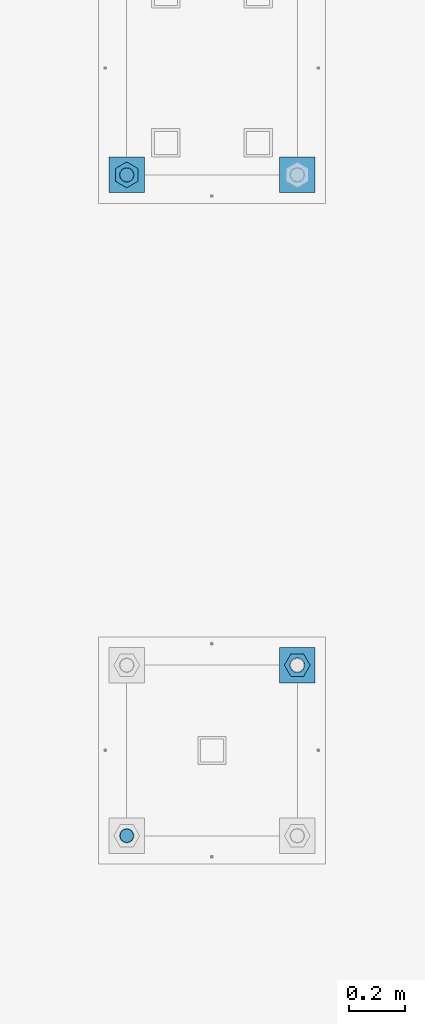
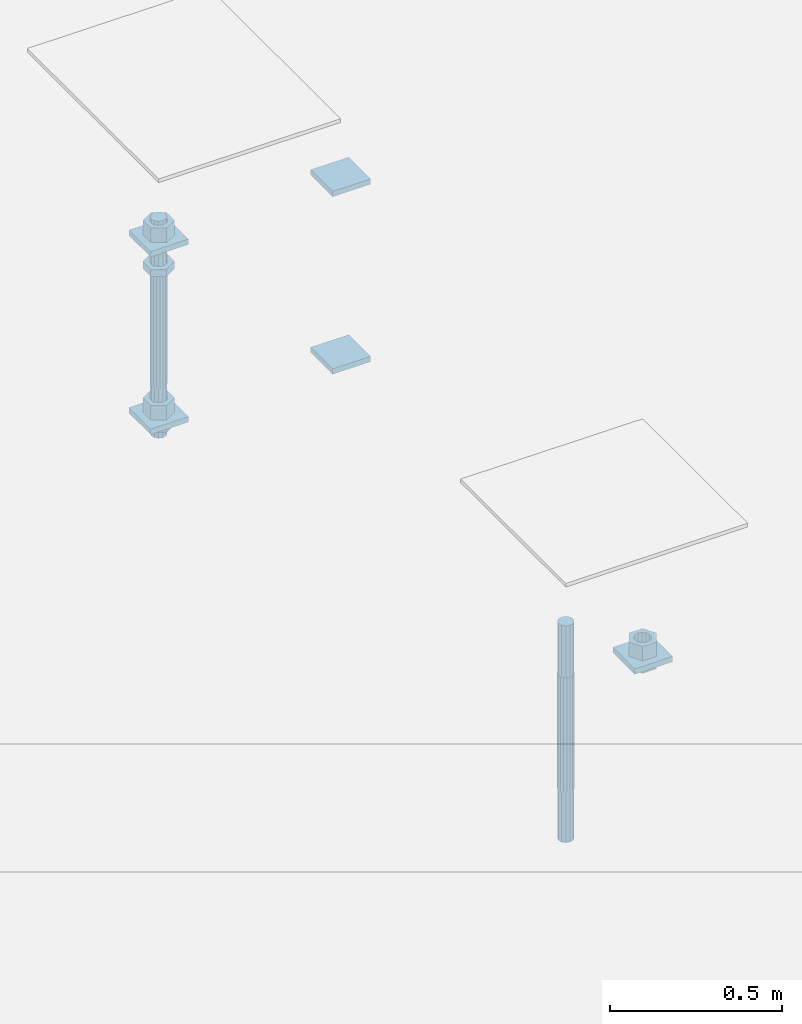
# One storey, part 2729 of 3843: 13 beams, 2 elements without a shape of their own.
"""IFC2X3 building model written with IfcOpenShell, lengths in millimetres."""

import ifcopenshell
import ifcopenshell.guid

model = None  # the IFC model being written
_history = None  # IfcOwnerHistory: only IFC2X3 demands one
_inside = {}  # id of a spatial element -> (the spatial element, [elements in it])
_under = {}  # id of a project, library or spatial element -> (it, [spatial elements below it])
_declared = {}  # id of a project -> (the project, [libraries it declares])
_typed = {}  # id of a type object -> (the type object, [elements of that type])
_made_of = {}  # id of a material, layer set ... -> (it, [elements and type objects made of it])


def new_model(schema):
    """Start an empty IFC model of exactly this schema.

    Asked for "IFC4X3", IfcOpenShell would pick the latest addendum, in which some entities
    have other attributes; the version numbers below select the first issue.
    IFC2X3 requires an IfcOwnerHistory on every rooted entity: one is made here for all.
    """
    global model, _history
    if schema == "IFC4X3":
        model = ifcopenshell.file(schema_version=(4, 3, 0, 0))
    else:
        model = ifcopenshell.file(schema=schema)
    _inside.clear()
    _under.clear()
    _declared.clear()
    _typed.clear()
    _made_of.clear()
    _history = None
    if model.schema == "IFC2X3":
        org = make("IfcOrganization", Name="unknown")
        user = make(
            "IfcPersonAndOrganization",
            ThePerson=make("IfcPerson", FamilyName="unknown"),
            TheOrganization=org,
        )
        app = make(
            "IfcApplication",
            ApplicationDeveloper=org,
            Version="unknown",
            ApplicationFullName="unknown",
            ApplicationIdentifier="unknown",
        )
        _history = make(
            "IfcOwnerHistory",
            OwningUser=user,
            OwningApplication=app,
            ChangeAction="ADDED",
            CreationDate=0,
        )
    return model


def make(cls, **values):
    """One entity of the class cls with the attributes given. An attribute that is None is left unset."""
    return model.create_entity(
        cls, **{name: value for name, value in values.items() if value is not None}
    )


def rooted(cls, **values):
    """An entity with a GlobalId (a new one), such as an element, a storey or a relation."""
    return make(cls, GlobalId=ifcopenshell.guid.new(), OwnerHistory=_history, **values)


def si_unit(unit_type, name, prefix=None):
    """IfcSIUnit, for example si_unit("LENGTHUNIT", "METRE", prefix="MILLI")."""
    return make("IfcSIUnit", UnitType=unit_type, Prefix=prefix, Name=name)


def assignment(units):
    """IfcUnitAssignment: the units of a project."""
    return None if units is None else make("IfcUnitAssignment", Units=units)


def point(xyz):
    """IfcCartesianPoint."""
    return None if xyz is None else make("IfcCartesianPoint", Coordinates=xyz)


def direction(xyz):
    """IfcDirection."""
    return None if xyz is None else make("IfcDirection", DirectionRatios=xyz)


def frame(location, z_axis=None, x_axis=None):
    """IfcAxis2Placement3D, a coordinate frame: its origin and axes. An axis left out is left unset."""
    return make(
        "IfcAxis2Placement3D",
        Location=point(location),
        Axis=direction(z_axis),
        RefDirection=direction(x_axis),
    )


def origin_with_axes():
    """The frame at (0, 0, 0) with the z axis (0, 0, 1) and the x axis (1, 0, 0) written out."""
    return frame((0.0, 0.0, 0.0), z_axis=(0.0, 0.0, 1.0), x_axis=(1.0, 0.0, 0.0))


def place(relative_to, where):
    """IfcLocalPlacement: puts the frame where relative to a parent placement (None: the world)."""
    return make(
        "IfcLocalPlacement", PlacementRelTo=relative_to, RelativePlacement=where
    )


def context(
    kind, dimensions, precision=None, world=None, true_north=None, identifier=None
):
    """IfcGeometricRepresentationContext, for example the 3D "Model" context."""
    return make(
        "IfcGeometricRepresentationContext",
        ContextIdentifier=identifier,
        ContextType=kind,
        CoordinateSpaceDimension=dimensions,
        Precision=precision,
        WorldCoordinateSystem=world,
        TrueNorth=true_north,
    )


def subcontext(parent, identifier, kind, view, scale=None):
    """IfcGeometricRepresentationSubContext, for example "Body" below "Model"."""
    return make(
        "IfcGeometricRepresentationSubContext",
        ContextIdentifier=identifier,
        ContextType=kind,
        ParentContext=parent,
        TargetScale=scale,
        TargetView=view,
    )


def project(units=None, contexts=None):
    """IfcProject with its units and contexts."""
    return rooted(
        "IfcProject",
        Name="project",
        RepresentationContexts=contexts,
        UnitsInContext=assignment(units),
    )


def spatial(cls, under=None, at=None, **own):
    """A site, building, storey or space (cls), placed at a placement, below another one or the project."""
    s = rooted(cls, ObjectPlacement=at, **own)
    if under is not None:
        _under.setdefault(under.id(), (under, []))[1].append(s)
    return s


def faces_of(points, faces, orient=None, outer=None):
    """IfcFace entities. A face is a list of loops; a loop is a list of indices into points, from 0.

    orient and outer hold one flag for each loop. By default every Orientation is true, the
    first loop of a face is its IfcFaceOuterBound and the others are IfcFaceBound.
    """
    made = []
    for i, loops in enumerate(faces):
        bounds = []
        for j, loop in enumerate(loops):
            is_outer = j == 0 if outer is None else outer[i][j]
            bounds.append(
                make(
                    "IfcFaceOuterBound" if is_outer else "IfcFaceBound",
                    Bound=make("IfcPolyLoop", Polygon=[points[k] for k in loop]),
                    Orientation=True if orient is None else orient[i][j],
                )
            )
        made.append(make("IfcFace", Bounds=bounds))
    return made


def faceted_brep(points, faces, orient=None, outer=None, voids=None):
    """IfcFacetedBrep: a solid bounded by flat faces; with voids (closed shells), ...WithVoids."""
    shared = [point(p) for p in points]
    hull = make("IfcClosedShell", CfsFaces=faces_of(shared, faces, orient, outer))
    if voids is None:
        return make("IfcFacetedBrep", Outer=hull)
    return make(
        "IfcFacetedBrepWithVoids",
        Outer=hull,
        Voids=[
            make(cls, CfsFaces=faces_of(shared, fs, o, b)) for cls, fs, o, b in voids
        ],
    )


def shape(context_of_items, identifier, shape_type, items):
    """IfcShapeRepresentation: the items that make up one representation, for example the "Body"."""
    return make(
        "IfcShapeRepresentation",
        ContextOfItems=context_of_items,
        RepresentationIdentifier=identifier,
        RepresentationType=shape_type,
        Items=items,
    )


def material(Name=None, Category=None):
    """IfcMaterial."""
    return make("IfcMaterial", Name=Name, Category=Category)


def made_of(thing, what):
    """Note that an element or type object is made of a material, layer set ...; save() writes the relation."""
    if what is not None:
        _made_of.setdefault(what.id(), (what, []))[1].append(thing)
    return thing


def type_object(cls, material=None, **own):
    """A type object (cls), such as IfcWallType, which elements share."""
    return made_of(rooted(cls, **own), material)


def element(
    cls,
    number,
    at=None,
    inside=None,
    cuts=None,
    type_object=None,
    material=None,
    context=None,
    identifier="Body",
    shape_type=None,
    held_by="IfcProductDefinitionShape",
    body=None,
    shapes=None,
    **own,
):
    """One element of the class cls, such as IfcWall. Its Tag is "e" and its number.

    at: its placement. inside: the storey or other place that contains it. cuts: it is an
    opening in that element (IfcRelVoidsElement). A single representation is given by context,
    identifier, shape_type and body (its items); several are given by shapes. held_by: the class
    of the entity that holds the representations. save() writes the other relations.
    """
    e = rooted(cls, Tag="e%d" % number, ObjectPlacement=at, **own)
    if body is not None:
        shapes = [shape(context, identifier, shape_type, body)]
    if shapes is not None:
        e.Representation = make(held_by, Representations=shapes)
    if inside is not None:
        _inside.setdefault(inside.id(), (inside, []))[1].append(e)
    if cuts is not None:
        rooted(
            "IfcRelVoidsElement", RelatingBuildingElement=cuts, RelatedOpeningElement=e
        )
    if type_object is not None:
        _typed.setdefault(type_object.id(), (type_object, []))[1].append(e)
    return made_of(e, material)


def aggregate(whole, parts):
    """IfcRelAggregates: a whole, such as a stair, and the parts it consists of."""
    return rooted("IfcRelAggregates", RelatingObject=whole, RelatedObjects=parts)


def save(model, path):
    """Write the relations noted so far, then the file.

    IfcRelAggregates (storeys below a building ...), IfcRelContainedInSpatialStructure (elements
    in a storey), IfcRelDefinesByType, IfcRelAssociatesMaterial and IfcRelDeclares: one each for
    every whole, place, type object, material and project.
    """
    for whole, parts in _under.values():
        aggregate(whole, parts)
    for where, things in _inside.values():
        rooted(
            "IfcRelContainedInSpatialStructure",
            RelatedElements=things,
            RelatingStructure=where,
        )
    for kind, things in _typed.values():
        rooted("IfcRelDefinesByType", RelatedObjects=things, RelatingType=kind)
    for what, things in _made_of.values():
        rooted("IfcRelAssociatesMaterial", RelatedObjects=things, RelatingMaterial=what)
    for by, libraries in _declared.values():
        rooted("IfcRelDeclares", RelatingContext=by, RelatedDefinitions=libraries)
    model.write(path)


model = new_model("IFC2X3")

# Units and contexts
model_context = context("Model", 3, precision=1e-05, world=origin_with_axes())
body_context = subcontext(model_context, "Body", "Model", "MODEL_VIEW")
ifc_project = project(units=[si_unit("LENGTHUNIT", "METRE", prefix="MILLI"), si_unit("AREAUNIT", "SQUARE_METRE"), si_unit("VOLUMEUNIT", "CUBIC_METRE"), si_unit("MASSUNIT", "GRAM", prefix="KILO"), si_unit("TIMEUNIT", "SECOND"), si_unit("PLANEANGLEUNIT", "RADIAN"), si_unit("SOLIDANGLEUNIT", "STERADIAN"), si_unit("THERMODYNAMICTEMPERATUREUNIT", "DEGREE_CELSIUS"), si_unit("LUMINOUSINTENSITYUNIT", "LUMEN")], contexts=[model_context])

# Site, building, storey
site_placement = place(None, origin_with_axes())
site = spatial("IfcSite", under=ifc_project, at=site_placement, CompositionType="ELEMENT")
building_placement = place(site_placement, origin_with_axes())
building = spatial("IfcBuilding", under=site, at=building_placement, Name="Undefined", CompositionType="ELEMENT")
storey_placement = place(building_placement, origin_with_axes())
storey = spatial("IfcBuildingStorey", under=building, at=storey_placement, Name="Undefined", CompositionType="ELEMENT", Elevation=0.0)

# Assembly, beams
assembly_1_placement = place(storey_placement, origin_with_axes())
assembly_1 = element("IfcElementAssembly", 1, at=assembly_1_placement, inside=storey, Name="TEMPLATE", AssemblyPlace="NOTDEFINED", PredefinedType="RIGID_FRAME")
ifc_material_1 = material(Name="STEEL/A36")
beam_type_1 = type_object("IfcBeamType", PredefinedType="NOTDEFINED")
beam_1_placement = place(assembly_1_placement, frame((111798.099998474, 38176.2, 29873.575), z_axis=(0.0, 1.0, 0.0), x_axis=(-1.0, 0.0, 0.0)))
beam_1 = element("IfcBeam", 2, at=beam_1_placement, type_object=beam_type_1, material=ifc_material_1, Name="WASHER_PLATE", context=body_context, shape_type="Brep", body=[
    faceted_brep([(0.0, 9.52500000000146, -63.5), (0.0, 9.52500000000146, 63.5), (127.0, 9.52500000000146, 63.5), (127.0, 9.52500000000146, -63.5), (0.0, -9.52500000000146, 63.5), (127.0, -9.52500000000146, 63.5), (0.0, -9.52500000000146, -63.5), (127.0, -9.52500000000146, -63.5)], [[[0, 1, 2, 3]], [[1, 4, 5, 2]], [[4, 6, 7, 5]], [[6, 0, 3, 7]], [[5, 7, 3, 2]], [[6, 4, 1, 0]]]),
])
beam_2_placement = place(assembly_1_placement, frame((112407.7, 38176.2, 29873.575), z_axis=(0.0, 1.0, 0.0), x_axis=(-1.0, 0.0, 0.0)))
beam_2 = element("IfcBeam", 3, at=beam_2_placement, type_object=beam_type_1, material=ifc_material_1, Name="WASHER_PLATE", context=body_context, shape_type="Brep", body=[
    faceted_brep([(0.0, 9.52500000000146, -63.5), (0.0, 9.52500000000146, 63.5), (127.0, 9.52500000000146, 63.5), (127.0, 9.52500000000146, -63.5), (0.0, -9.52500000000146, 63.5), (127.0, -9.52500000000146, 63.5), (0.0, -9.52500000000146, -63.5), (127.0, -9.52500000000146, -63.5)], [[[0, 1, 2, 3]], [[1, 4, 5, 2]], [[4, 6, 7, 5]], [[6, 0, 3, 7]], [[5, 7, 3, 2]], [[6, 4, 1, 0]]]),
])
beam_3_placement = place(assembly_1_placement, frame((111798.099998474, 38176.2, 29244.925), z_axis=(0.0, 1.0, 0.0), x_axis=(-1.0, 0.0, 0.0)))
beam_3 = element("IfcBeam", 4, at=beam_3_placement, type_object=beam_type_1, material=ifc_material_1, Name="WASHER_PLATE", context=body_context, shape_type="Brep", body=[
    faceted_brep([(0.0, 9.52500000000146, -63.5), (0.0, 9.52500000000146, 63.5), (127.0, 9.52500000000146, 63.5), (127.0, 9.52500000000146, -63.5), (0.0, -9.52500000000146, 63.5), (127.0, -9.52500000000146, 63.5), (0.0, -9.52500000000146, -63.5), (127.0, -9.52500000000146, -63.5)], [[[0, 1, 2, 3]], [[1, 4, 5, 2]], [[4, 6, 7, 5]], [[6, 0, 3, 7]], [[5, 7, 3, 2]], [[6, 4, 1, 0]]]),
])
beam_4_placement = place(assembly_1_placement, frame((112407.7, 38176.2, 29244.925), z_axis=(0.0, 1.0, 0.0), x_axis=(-1.0, 0.0, 0.0)))
beam_4 = element("IfcBeam", 5, at=beam_4_placement, type_object=beam_type_1, material=ifc_material_1, Name="WASHER_PLATE", context=body_context, shape_type="Brep", body=[
    faceted_brep([(0.0, 9.52500000000146, -63.5), (0.0, 9.52500000000146, 63.5), (127.0, 9.52500000000146, 63.5), (127.0, 9.52500000000146, -63.5), (0.0, -9.52500000000146, 63.5), (127.0, -9.52500000000146, 63.5), (0.0, -9.52500000000146, -63.5), (127.0, -9.52500000000146, -63.5)], [[[0, 1, 2, 3]], [[1, 4, 5, 2]], [[4, 6, 7, 5]], [[6, 0, 3, 7]], [[5, 7, 3, 2]], [[6, 4, 1, 0]]]),
])

# Assembly, beam
assembly_2_placement = place(storey_placement, origin_with_axes())
assembly_2 = element("IfcElementAssembly", 6, at=assembly_2_placement, inside=storey, Name="TEMPLATE", AssemblyPlace="NOTDEFINED", PredefinedType="RIGID_FRAME")
beam_5_placement = place(assembly_2_placement, frame((112344.2, 36360.1000015259, 29244.925), z_axis=(1.0, 0.0, 0.0), x_axis=(0.0, 1.0, 0.0)))
beam_5 = element("IfcBeam", 7, at=beam_5_placement, type_object=beam_type_1, material=ifc_material_1, Name="WASHER_PLATE", context=body_context, shape_type="Brep", body=[
    faceted_brep([(0.0, 9.52500000000146, -63.5), (0.0, 9.52500000000146, 63.5), (127.0, 9.52500000000146, 63.5), (127.0, 9.52500000000146, -63.5), (0.0, -9.52500000000146, 63.5), (127.0, -9.52500000000146, 63.5), (0.0, -9.52500000000146, -63.5), (127.0, -9.52500000000146, -63.5)], [[[0, 1, 2, 3]], [[1, 4, 5, 2]], [[4, 6, 7, 5]], [[6, 0, 3, 7]], [[5, 7, 3, 2]], [[6, 4, 1, 0]]]),
])

# Beam
beam_type_2 = type_object("IfcBeamType", Name="2_HALF_NUT", PredefinedType="NOTDEFINED")
beam_6_placement = place(assembly_1_placement, frame((111734.599998474, 38176.2, 29787.85), z_axis=(-1.0, 0.0, 0.0), x_axis=(0.0, 0.0, -1.0)))
beam_6 = element("IfcBeam", 8, at=beam_6_placement, type_object=beam_type_2, material=ifc_material_1, Name="NUT", ObjectType="2_HALF_NUT", context=body_context, shape_type="Brep", body=[
    faceted_brep([(0.0, -46.0369987487793, 0.0), (0.0, -23.0184993743896, -39.869213104248), (25.4000000000015, -23.0184993743896, -39.869213104248), (25.4000000000015, -46.0369987487793, 0.0), (0.0, 23.0184993743896, -39.869213104248), (25.4000000000015, 23.0184993743896, -39.869213104248), (0.0, 46.0369987487793, 0.0), (25.4000000000015, 46.0369987487793, 0.0), (0.0, 23.0184993743896, 39.869213104248), (25.4000000000015, 23.0184993743896, 39.869213104248), (0.0, -23.0184993743896, 39.869213104248), (25.4000000000015, -23.0184993743896, 39.869213104248), (0.0, 0.0, 26.1940002441406), (0.0, 11.3650617044477, 23.5999013092805), (25.4000000000015, 11.3650617044477, 23.5999013092805), (25.4000000000015, 0.0, 26.1940002441406), (0.0, 20.4791109456419, 16.3316083006721), (25.4000000000015, 20.4791109456419, 16.3316083006721), (0.0, 25.5370200498292, 5.82867859874386), (25.4000000000015, 25.5370200498292, 5.82867859874386), (0.0, 25.5370200498292, -5.82867859874386), (25.4000000000015, 25.5370200498292, -5.82867859874386), (0.0, 20.4791109456419, -16.3316083006721), (25.4000000000015, 20.4791109456419, -16.3316083006721), (0.0, 11.3650617044477, -23.5999013092805), (25.4000000000015, 11.3650617044477, -23.5999013092805), (0.0, 0.0, -26.1940002441406), (25.4000000000015, 0.0, -26.1940002441406), (0.0, -11.3650617044477, -23.5999013092805), (25.4000000000015, -11.3650617044477, -23.5999013092805), (0.0, -20.4791109456419, -16.3316083006721), (25.4000000000015, -20.4791109456419, -16.3316083006721), (0.0, -25.5370200498292, -5.82867859874386), (25.4000000000015, -25.5370200498292, -5.82867859874386), (0.0, -25.5370200498292, 5.82867859874386), (25.4000000000015, -25.5370200498292, 5.82867859874386), (0.0, -20.4791109456419, 16.3316083006721), (25.4000000000015, -20.4791109456419, 16.3316083006721), (0.0, -11.3650617044477, 23.5999013092805), (25.4000000000015, -11.3650617044477, 23.5999013092805)], [[[0, 1, 2, 3]], [[1, 4, 5, 2]], [[4, 6, 7, 5]], [[6, 8, 9, 7]], [[8, 10, 11, 9]], [[10, 0, 3, 11]], [[12, 13, 14, 15]], [[13, 16, 17, 14]], [[16, 18, 19, 17]], [[18, 20, 21, 19]], [[20, 22, 23, 21]], [[22, 24, 25, 23]], [[24, 26, 27, 25]], [[26, 28, 29, 27]], [[28, 30, 31, 29]], [[30, 32, 33, 31]], [[32, 34, 35, 33]], [[34, 36, 37, 35]], [[36, 38, 39, 37]], [[38, 12, 15, 39]], [[5, 7, 9, 11, 3, 2], [17, 19, 21, 23, 25, 27, 29, 31, 33, 35, 37, 39, 15, 14]], [[10, 8, 6, 4, 1, 0], [38, 36, 34, 32, 30, 28, 26, 24, 22, 20, 18, 16, 13, 12]]]),
])

beam_7_placement = place(assembly_1_placement, frame((111734.599998474, 38176.2, 29235.4), z_axis=(-1.0, 0.0, 0.0), x_axis=(0.0, 0.0, -1.0)))
beam_7 = element("IfcBeam", 9, at=beam_7_placement, type_object=beam_type_2, material=ifc_material_1, Name="NUT", ObjectType="2_HALF_NUT", context=body_context, shape_type="Brep", body=[
    faceted_brep([(0.0, -46.0369987487793, 0.0), (0.0, -23.0184993743896, -39.869213104248), (25.4000000000015, -23.0184993743896, -39.869213104248), (25.4000000000015, -46.0369987487793, 0.0), (0.0, 23.0184993743896, -39.869213104248), (25.4000000000015, 23.0184993743896, -39.869213104248), (0.0, 46.0369987487793, 0.0), (25.4000000000015, 46.0369987487793, 0.0), (0.0, 23.0184993743896, 39.869213104248), (25.4000000000015, 23.0184993743896, 39.869213104248), (0.0, -23.0184993743896, 39.869213104248), (25.4000000000015, -23.0184993743896, 39.869213104248), (0.0, 0.0, 26.1940002441406), (0.0, 11.3650617044477, 23.5999013092805), (25.4000000000015, 11.3650617044477, 23.5999013092805), (25.4000000000015, 0.0, 26.1940002441406), (0.0, 20.4791109456419, 16.3316083006721), (25.4000000000015, 20.4791109456419, 16.3316083006721), (0.0, 25.5370200498292, 5.82867859874386), (25.4000000000015, 25.5370200498292, 5.82867859874386), (0.0, 25.5370200498292, -5.82867859874386), (25.4000000000015, 25.5370200498292, -5.82867859874386), (0.0, 20.4791109456419, -16.3316083006721), (25.4000000000015, 20.4791109456419, -16.3316083006721), (0.0, 11.3650617044477, -23.5999013092805), (25.4000000000015, 11.3650617044477, -23.5999013092805), (0.0, 0.0, -26.1940002441406), (25.4000000000015, 0.0, -26.1940002441406), (0.0, -11.3650617044477, -23.5999013092805), (25.4000000000015, -11.3650617044477, -23.5999013092805), (0.0, -20.4791109456419, -16.3316083006721), (25.4000000000015, -20.4791109456419, -16.3316083006721), (0.0, -25.5370200498292, -5.82867859874386), (25.4000000000015, -25.5370200498292, -5.82867859874386), (0.0, -25.5370200498292, 5.82867859874386), (25.4000000000015, -25.5370200498292, 5.82867859874386), (0.0, -20.4791109456419, 16.3316083006721), (25.4000000000015, -20.4791109456419, 16.3316083006721), (0.0, -11.3650617044477, 23.5999013092805), (25.4000000000015, -11.3650617044477, 23.5999013092805)], [[[0, 1, 2, 3]], [[1, 4, 5, 2]], [[4, 6, 7, 5]], [[6, 8, 9, 7]], [[8, 10, 11, 9]], [[10, 0, 3, 11]], [[12, 13, 14, 15]], [[13, 16, 17, 14]], [[16, 18, 19, 17]], [[18, 20, 21, 19]], [[20, 22, 23, 21]], [[22, 24, 25, 23]], [[24, 26, 27, 25]], [[26, 28, 29, 27]], [[28, 30, 31, 29]], [[30, 32, 33, 31]], [[32, 34, 35, 33]], [[34, 36, 37, 35]], [[36, 38, 39, 37]], [[38, 12, 15, 39]], [[5, 7, 9, 11, 3, 2], [17, 19, 21, 23, 25, 27, 29, 31, 33, 35, 37, 39, 15, 14]], [[10, 8, 6, 4, 1, 0], [38, 36, 34, 32, 30, 28, 26, 24, 22, 20, 18, 16, 13, 12]]]),
])

beam_8_placement = place(assembly_2_placement, frame((112344.2, 36423.6000015259, 29235.4), z_axis=(0.0, 1.0, 0.0), x_axis=(0.0, 0.0, -1.0)))
beam_8 = element("IfcBeam", 10, at=beam_8_placement, type_object=beam_type_2, material=ifc_material_1, Name="NUT", ObjectType="2_HALF_NUT", context=body_context, shape_type="Brep", body=[
    faceted_brep([(0.0, -46.0369987487793, 0.0), (0.0, -23.0184993743896, -39.869213104248), (25.4000000000015, -23.0184993743896, -39.869213104248), (25.4000000000015, -46.0369987487793, 0.0), (0.0, 23.0184993743896, -39.869213104248), (25.4000000000015, 23.0184993743896, -39.869213104248), (0.0, 46.0369987487793, 0.0), (25.4000000000015, 46.0369987487793, 0.0), (0.0, 23.0184993743896, 39.869213104248), (25.4000000000015, 23.0184993743896, 39.869213104248), (0.0, -23.0184993743896, 39.869213104248), (25.4000000000015, -23.0184993743896, 39.869213104248), (0.0, 0.0, 26.1940002441406), (0.0, 11.3650617044477, 23.5999013092805), (25.4000000000015, 11.3650617044477, 23.5999013092805), (25.4000000000015, 0.0, 26.1940002441406), (0.0, 20.4791109456419, 16.3316083006721), (25.4000000000015, 20.4791109456419, 16.3316083006721), (0.0, 25.5370200498292, 5.82867859874386), (25.4000000000015, 25.5370200498292, 5.82867859874386), (0.0, 25.5370200498292, -5.82867859874386), (25.4000000000015, 25.5370200498292, -5.82867859874386), (0.0, 20.4791109456419, -16.3316083006721), (25.4000000000015, 20.4791109456419, -16.3316083006721), (0.0, 11.3650617044477, -23.5999013092805), (25.4000000000015, 11.3650617044477, -23.5999013092805), (0.0, 0.0, -26.1940002441406), (25.4000000000015, 0.0, -26.1940002441406), (0.0, -11.3650617044477, -23.5999013092805), (25.4000000000015, -11.3650617044477, -23.5999013092805), (0.0, -20.4791109456419, -16.3316083006721), (25.4000000000015, -20.4791109456419, -16.3316083006721), (0.0, -25.5370200498292, -5.82867859874386), (25.4000000000015, -25.5370200498292, -5.82867859874386), (0.0, -25.5370200498292, 5.82867859874386), (25.4000000000015, -25.5370200498292, 5.82867859874386), (0.0, -20.4791109456419, 16.3316083006721), (25.4000000000015, -20.4791109456419, 16.3316083006721), (0.0, -11.3650617044477, 23.5999013092805), (25.4000000000015, -11.3650617044477, 23.5999013092805)], [[[0, 1, 2, 3]], [[1, 4, 5, 2]], [[4, 6, 7, 5]], [[6, 8, 9, 7]], [[8, 10, 11, 9]], [[10, 0, 3, 11]], [[12, 13, 14, 15]], [[13, 16, 17, 14]], [[16, 18, 19, 17]], [[18, 20, 21, 19]], [[20, 22, 23, 21]], [[22, 24, 25, 23]], [[24, 26, 27, 25]], [[26, 28, 29, 27]], [[28, 30, 31, 29]], [[30, 32, 33, 31]], [[32, 34, 35, 33]], [[34, 36, 37, 35]], [[36, 38, 39, 37]], [[38, 12, 15, 39]], [[5, 7, 9, 11, 3, 2], [17, 19, 21, 23, 25, 27, 29, 31, 33, 35, 37, 39, 15, 14]], [[10, 8, 6, 4, 1, 0], [38, 36, 34, 32, 30, 28, 26, 24, 22, 20, 18, 16, 13, 12]]]),
])

beam_type_3 = type_object("IfcBeamType", Name="2_HEAVY_HEX_NUT", PredefinedType="NOTDEFINED")
beam_9_placement = place(assembly_1_placement, frame((111734.599998474, 38176.2, 29933.9), z_axis=(-1.0, 0.0, 0.0), x_axis=(0.0, 0.0, -1.0)))
beam_9 = element("IfcBeam", 11, at=beam_9_placement, type_object=beam_type_3, material=ifc_material_1, Name="NUT", ObjectType="2_HEAVY_HEX_NUT", context=body_context, shape_type="Brep", body=[
    faceted_brep([(0.0, -46.0369987487793, 0.0), (0.0, -23.0184993743896, -39.869213104248), (50.7999999999993, -23.0184993743896, -39.869213104248), (50.7999999999993, -46.0369987487793, 0.0), (0.0, 23.0184993743896, -39.869213104248), (50.7999999999993, 23.0184993743896, -39.869213104248), (0.0, 46.0369987487793, 0.0), (50.7999999999993, 46.0369987487793, 0.0), (0.0, 23.0184993743896, 39.869213104248), (50.7999999999993, 23.0184993743896, 39.869213104248), (0.0, -23.0184993743896, 39.869213104248), (50.7999999999993, -23.0184993743896, 39.869213104248), (0.0, 0.0, 26.1940002441406), (0.0, 11.3650617044477, 23.5999013092805), (50.7999999999993, 11.3650617044477, 23.5999013092805), (50.7999999999993, 0.0, 26.1940002441406), (0.0, 20.4791109456419, 16.3316083006721), (50.7999999999993, 20.4791109456419, 16.3316083006721), (0.0, 25.5370200498292, 5.82867859874386), (50.7999999999993, 25.5370200498292, 5.82867859874386), (0.0, 25.5370200498292, -5.82867859874386), (50.7999999999993, 25.5370200498292, -5.82867859874386), (0.0, 20.4791109456419, -16.3316083006721), (50.7999999999993, 20.4791109456419, -16.3316083006721), (0.0, 11.3650617044477, -23.5999013092805), (50.7999999999993, 11.3650617044477, -23.5999013092805), (0.0, 0.0, -26.1940002441406), (50.7999999999993, 0.0, -26.1940002441406), (0.0, -11.3650617044477, -23.5999013092805), (50.7999999999993, -11.3650617044477, -23.5999013092805), (0.0, -20.4791109456419, -16.3316083006721), (50.7999999999993, -20.4791109456419, -16.3316083006721), (0.0, -25.5370200498292, -5.82867859874386), (50.7999999999993, -25.5370200498292, -5.82867859874386), (0.0, -25.5370200498292, 5.82867859874386), (50.7999999999993, -25.5370200498292, 5.82867859874386), (0.0, -20.4791109456419, 16.3316083006721), (50.7999999999993, -20.4791109456419, 16.3316083006721), (0.0, -11.3650617044477, 23.5999013092805), (50.7999999999993, -11.3650617044477, 23.5999013092805)], [[[0, 1, 2, 3]], [[1, 4, 5, 2]], [[4, 6, 7, 5]], [[6, 8, 9, 7]], [[8, 10, 11, 9]], [[10, 0, 3, 11]], [[12, 13, 14, 15]], [[13, 16, 17, 14]], [[16, 18, 19, 17]], [[18, 20, 21, 19]], [[20, 22, 23, 21]], [[22, 24, 25, 23]], [[24, 26, 27, 25]], [[26, 28, 29, 27]], [[28, 30, 31, 29]], [[30, 32, 33, 31]], [[32, 34, 35, 33]], [[34, 36, 37, 35]], [[36, 38, 39, 37]], [[38, 12, 15, 39]], [[5, 7, 9, 11, 3, 2], [17, 19, 21, 23, 25, 27, 29, 31, 33, 35, 37, 39, 15, 14]], [[10, 8, 6, 4, 1, 0], [38, 36, 34, 32, 30, 28, 26, 24, 22, 20, 18, 16, 13, 12]]]),
])

beam_10_placement = place(assembly_1_placement, frame((111734.599998474, 38176.2, 29305.25), z_axis=(-1.0, 0.0, 0.0), x_axis=(0.0, 0.0, -1.0)))
beam_10 = element("IfcBeam", 12, at=beam_10_placement, type_object=beam_type_3, material=ifc_material_1, Name="NUT", ObjectType="2_HEAVY_HEX_NUT", context=body_context, shape_type="Brep", body=[
    faceted_brep([(0.0, -46.0369987487793, 0.0), (0.0, -23.0184993743896, -39.869213104248), (50.7999999999993, -23.0184993743896, -39.869213104248), (50.7999999999993, -46.0369987487793, 0.0), (0.0, 23.0184993743896, -39.869213104248), (50.7999999999993, 23.0184993743896, -39.869213104248), (0.0, 46.0369987487793, 0.0), (50.7999999999993, 46.0369987487793, 0.0), (0.0, 23.0184993743896, 39.869213104248), (50.7999999999993, 23.0184993743896, 39.869213104248), (0.0, -23.0184993743896, 39.869213104248), (50.7999999999993, -23.0184993743896, 39.869213104248), (0.0, 0.0, 26.1940002441406), (0.0, 11.3650617044477, 23.5999013092805), (50.7999999999993, 11.3650617044477, 23.5999013092805), (50.7999999999993, 0.0, 26.1940002441406), (0.0, 20.4791109456419, 16.3316083006721), (50.7999999999993, 20.4791109456419, 16.3316083006721), (0.0, 25.5370200498292, 5.82867859874386), (50.7999999999993, 25.5370200498292, 5.82867859874386), (0.0, 25.5370200498292, -5.82867859874386), (50.7999999999993, 25.5370200498292, -5.82867859874386), (0.0, 20.4791109456419, -16.3316083006721), (50.7999999999993, 20.4791109456419, -16.3316083006721), (0.0, 11.3650617044477, -23.5999013092805), (50.7999999999993, 11.3650617044477, -23.5999013092805), (0.0, 0.0, -26.1940002441406), (50.7999999999993, 0.0, -26.1940002441406), (0.0, -11.3650617044477, -23.5999013092805), (50.7999999999993, -11.3650617044477, -23.5999013092805), (0.0, -20.4791109456419, -16.3316083006721), (50.7999999999993, -20.4791109456419, -16.3316083006721), (0.0, -25.5370200498292, -5.82867859874386), (50.7999999999993, -25.5370200498292, -5.82867859874386), (0.0, -25.5370200498292, 5.82867859874386), (50.7999999999993, -25.5370200498292, 5.82867859874386), (0.0, -20.4791109456419, 16.3316083006721), (50.7999999999993, -20.4791109456419, 16.3316083006721), (0.0, -11.3650617044477, 23.5999013092805), (50.7999999999993, -11.3650617044477, 23.5999013092805)], [[[0, 1, 2, 3]], [[1, 4, 5, 2]], [[4, 6, 7, 5]], [[6, 8, 9, 7]], [[8, 10, 11, 9]], [[10, 0, 3, 11]], [[12, 13, 14, 15]], [[13, 16, 17, 14]], [[16, 18, 19, 17]], [[18, 20, 21, 19]], [[20, 22, 23, 21]], [[22, 24, 25, 23]], [[24, 26, 27, 25]], [[26, 28, 29, 27]], [[28, 30, 31, 29]], [[30, 32, 33, 31]], [[32, 34, 35, 33]], [[34, 36, 37, 35]], [[36, 38, 39, 37]], [[38, 12, 15, 39]], [[5, 7, 9, 11, 3, 2], [17, 19, 21, 23, 25, 27, 29, 31, 33, 35, 37, 39, 15, 14]], [[10, 8, 6, 4, 1, 0], [38, 36, 34, 32, 30, 28, 26, 24, 22, 20, 18, 16, 13, 12]]]),
])

beam_11_placement = place(assembly_2_placement, frame((112344.2, 36423.6000015259, 29305.25), z_axis=(0.0, 1.0, 0.0), x_axis=(0.0, 0.0, -1.0)))
beam_11 = element("IfcBeam", 13, at=beam_11_placement, type_object=beam_type_3, material=ifc_material_1, Name="NUT", ObjectType="2_HEAVY_HEX_NUT", context=body_context, shape_type="Brep", body=[
    faceted_brep([(0.0, -46.0369987487793, 0.0), (0.0, -23.0184993743896, -39.869213104248), (50.7999999999993, -23.0184993743896, -39.869213104248), (50.7999999999993, -46.0369987487793, 0.0), (0.0, 23.0184993743896, -39.869213104248), (50.7999999999993, 23.0184993743896, -39.869213104248), (0.0, 46.0369987487793, 0.0), (50.7999999999993, 46.0369987487793, 0.0), (0.0, 23.0184993743896, 39.869213104248), (50.7999999999993, 23.0184993743896, 39.869213104248), (0.0, -23.0184993743896, 39.869213104248), (50.7999999999993, -23.0184993743896, 39.869213104248), (0.0, 0.0, 26.1940002441406), (0.0, 11.3650617044477, 23.5999013092805), (50.7999999999993, 11.3650617044477, 23.5999013092805), (50.7999999999993, 0.0, 26.1940002441406), (0.0, 20.4791109456419, 16.3316083006721), (50.7999999999993, 20.4791109456419, 16.3316083006721), (0.0, 25.5370200498292, 5.82867859874386), (50.7999999999993, 25.5370200498292, 5.82867859874386), (0.0, 25.5370200498292, -5.82867859874386), (50.7999999999993, 25.5370200498292, -5.82867859874386), (0.0, 20.4791109456419, -16.3316083006721), (50.7999999999993, 20.4791109456419, -16.3316083006721), (0.0, 11.3650617044477, -23.5999013092805), (50.7999999999993, 11.3650617044477, -23.5999013092805), (0.0, 0.0, -26.1940002441406), (50.7999999999993, 0.0, -26.1940002441406), (0.0, -11.3650617044477, -23.5999013092805), (50.7999999999993, -11.3650617044477, -23.5999013092805), (0.0, -20.4791109456419, -16.3316083006721), (50.7999999999993, -20.4791109456419, -16.3316083006721), (0.0, -25.5370200498292, -5.82867859874386), (50.7999999999993, -25.5370200498292, -5.82867859874386), (0.0, -25.5370200498292, 5.82867859874386), (50.7999999999993, -25.5370200498292, 5.82867859874386), (0.0, -20.4791109456419, 16.3316083006721), (50.7999999999993, -20.4791109456419, 16.3316083006721), (0.0, -11.3650617044477, 23.5999013092805), (50.7999999999993, -11.3650617044477, 23.5999013092805)], [[[0, 1, 2, 3]], [[1, 4, 5, 2]], [[4, 6, 7, 5]], [[6, 8, 9, 7]], [[8, 10, 11, 9]], [[10, 0, 3, 11]], [[12, 13, 14, 15]], [[13, 16, 17, 14]], [[16, 18, 19, 17]], [[18, 20, 21, 19]], [[20, 22, 23, 21]], [[22, 24, 25, 23]], [[24, 26, 27, 25]], [[26, 28, 29, 27]], [[28, 30, 31, 29]], [[30, 32, 33, 31]], [[32, 34, 35, 33]], [[34, 36, 37, 35]], [[36, 38, 39, 37]], [[38, 12, 15, 39]], [[5, 7, 9, 11, 3, 2], [17, 19, 21, 23, 25, 27, 29, 31, 33, 35, 37, 39, 15, 14]], [[10, 8, 6, 4, 1, 0], [38, 36, 34, 32, 30, 28, 26, 24, 22, 20, 18, 16, 13, 12]]]),
])

ifc_material_2 = material()
beam_type_4 = type_object("IfcBeamType", PredefinedType="NOTDEFINED")
beam_12_placement = place(assembly_1_placement, frame((111734.599998474, 38176.2, 29762.45), z_axis=(-1.0, 0.0, 0.0), x_axis=(0.0, 0.0, -1.0)))
beam_12 = element("IfcBeam", 14, at=beam_12_placement, type_object=beam_type_4, material=ifc_material_2, Name="ANCHOR_ROD", context=body_context, shape_type="Brep", body=[
    faceted_brep([(-184.150000000001, -21.217622392709, 12.25), (-184.150000000001, -12.2499999999854, 21.2176223927163), (-184.150000000001, 1.45519152283669e-11, 24.5), (-184.150000000001, 12.2500000000146, 21.2176223927163), (-184.150000000001, 21.2176223927381, 12.25), (-184.150000000001, 24.5000000000146, 0.0), (-184.150000000001, 21.2176223927381, -12.25), (-184.150000000001, 12.2500000000146, -21.2176223927163), (-184.150000000001, 1.45519152283669e-11, -24.5), (-184.150000000001, -12.2499999999854, -21.2176223927163), (-184.150000000001, -21.217622392709, -12.25), (-184.150000000001, -24.4999999999854, 0.0), (0.0, 24.5000000000146, 0.0), (0.0, 21.2176223927381, -12.25), (0.0, 12.2500000000146, -21.2176223927163), (0.0, 1.45519152283669e-11, -24.5), (0.0, -12.2499999999854, -21.2176223927163), (0.0, -21.217622392709, -12.25), (0.0, -24.4999999999854, 0.0), (0.0, -21.217622392709, 12.25), (0.0, -12.2499999999854, 21.2176223927163), (0.0, 1.45519152283669e-11, 24.5), (0.0, 12.2500000000146, 21.2176223927163), (0.0, 21.2176223927381, 12.25), (0.0, -23.4665401257807, 9.72015918207035), (0.0, -17.9605122421344, 17.9605122421417), (0.0, -9.72015918207762, 23.466540125788), (0.0, 0.0, 25.4000000000015), (0.0, 9.72015918207762, 23.466540125788), (0.0, 17.9605122421344, 17.9605122421417), (0.0, 23.4665401257807, 9.72015918207035), (0.0, 25.3999996185303, 0.0), (0.0, 23.4665401257807, -9.72015918207035), (0.0, 17.9605122421344, -17.9605122421417), (0.0, 9.72015918207762, -23.466540125788), (0.0, 0.0, -25.4000000000015), (0.0, -9.72015918207762, -23.466540125788), (0.0, -17.9605122421344, -17.9605122421417), (0.0, -23.4665401257807, -9.72015918207035), (0.0, -25.3999996185303, 0.0), (406.399999999998, -25.3999999999942, 0.0), (406.399999999998, -23.4665401257807, 9.72015918207035), (406.399999999998, -17.9605122421344, 17.9605122421417), (406.399999999998, -9.72015918207762, 23.466540125788), (406.399999999998, 0.0, 25.4000000000015), (406.399999999998, 9.72015918207762, 23.466540125788), (406.399999999998, 17.9605122421344, 17.9605122421417), (406.399999999998, 23.4665401257807, 9.72015918207035), (406.399999999998, 25.3999999999942, 0.0), (406.399999999998, 23.4665401257807, -9.72015918207035), (406.399999999998, 17.9605122421344, -17.9605122421417), (406.399999999998, 9.72015918207762, -23.466540125788), (406.399999999998, 0.0, -25.4000000000015), (406.399999999998, -9.72015918207762, -23.466540125788), (406.399999999998, -17.9605122421344, -17.9605122421417), (406.399999999998, -23.4665401257807, -9.72015918207035), (406.399999999998, -12.2499999999854, 21.2176223927163), (406.399999999998, 1.45519152283669e-11, 24.5), (406.399999999998, 12.2500000000146, 21.2176223927163), (406.399999999998, 21.2176223927381, 12.25), (406.399999999998, 24.5000000000146, 0.0), (406.399999999998, 21.2176223927381, -12.25), (406.399999999998, 12.2500000000146, -21.2176223927163), (406.399999999998, 1.45519152283669e-11, -24.5), (406.399999999998, -12.2499999999854, -21.2176223927163), (406.399999999998, -21.217622392709, -12.25), (406.399999999998, -24.4999999999854, 0.0), (406.399999999998, -21.217622392709, 12.25), (584.200000000001, -12.2499999999854, -21.2176223927163), (584.200000000001, 1.45519152283669e-11, -24.5), (584.200000000001, 12.2500000000146, -21.2176223927163), (584.200000000001, 21.2176223927381, -12.25), (584.200000000001, 24.5000000000146, 0.0), (584.200000000001, 21.2176223927381, 12.25), (584.200000000001, 12.2500000000146, 21.2176223927163), (584.200000000001, 1.45519152283669e-11, 24.5), (584.200000000001, -12.2499999999854, 21.2176223927163), (584.200000000001, -21.217622392709, 12.25), (584.200000000001, -24.4999999999854, 0.0), (584.200000000001, -21.217622392709, -12.25)], [[[0, 1, 2, 3, 4, 5, 6, 7, 8, 9, 10, 11]], [[6, 5, 12, 13]], [[7, 6, 13, 14]], [[8, 7, 14, 15]], [[9, 8, 15, 16]], [[10, 9, 16, 17]], [[11, 10, 17, 18]], [[0, 11, 18, 19]], [[1, 0, 19, 20]], [[2, 1, 20, 21]], [[3, 2, 21, 22]], [[4, 3, 22, 23]], [[5, 4, 23, 12]], [[24, 25, 26, 27, 28, 29, 30, 31, 32, 33, 34, 35, 36, 37, 38, 39], [22, 21, 20, 19, 18, 17, 16, 15, 14, 13, 12, 23]], [[24, 39, 40, 41]], [[25, 24, 41, 42]], [[26, 25, 42, 43]], [[27, 26, 43, 44]], [[28, 27, 44, 45]], [[29, 28, 45, 46]], [[30, 29, 46, 47]], [[31, 30, 47, 48]], [[32, 31, 48, 49]], [[33, 32, 49, 50]], [[34, 33, 50, 51]], [[35, 34, 51, 52]], [[36, 35, 52, 53]], [[37, 36, 53, 54]], [[38, 37, 54, 55]], [[39, 38, 55, 40]], [[54, 53, 52, 51, 50, 49, 48, 47, 46, 45, 44, 43, 42, 41, 40, 55], [56, 57, 58, 59, 60, 61, 62, 63, 64, 65, 66, 67]], [[68, 69, 70, 71, 72, 73, 74, 75, 76, 77, 78, 79]], [[76, 75, 57, 56]], [[77, 76, 56, 67]], [[78, 77, 67, 66]], [[79, 78, 66, 65]], [[68, 79, 65, 64]], [[69, 68, 64, 63]], [[70, 69, 63, 62]], [[71, 70, 62, 61]], [[72, 71, 61, 60]], [[73, 72, 60, 59]], [[74, 73, 59, 58]], [[75, 74, 58, 57]]]),
])

aggregate(assembly_1, [beam_1, beam_2, beam_3, beam_6, beam_9, beam_10, beam_7, beam_12, beam_4])

beam_13_placement = place(assembly_2_placement, frame((111734.6, 35814.0000015259, 29762.45), z_axis=(0.0, 1.0, 0.0), x_axis=(0.0, 0.0, -1.0)))
beam_13 = element("IfcBeam", 15, at=beam_13_placement, type_object=beam_type_4, material=ifc_material_2, Name="ANCHOR_ROD", context=body_context, shape_type="Brep", body=[
    faceted_brep([(-184.150000000001, -21.217622392709, 12.25), (-184.150000000001, -12.2499999999854, 21.2176223927163), (-184.150000000001, 1.45519152283669e-11, 24.5), (-184.150000000001, 12.2500000000146, 21.2176223927163), (-184.150000000001, 21.2176223927381, 12.25), (-184.150000000001, 24.5000000000146, 0.0), (-184.150000000001, 21.2176223927381, -12.25), (-184.150000000001, 12.2500000000146, -21.2176223927163), (-184.150000000001, 1.45519152283669e-11, -24.5), (-184.150000000001, -12.2499999999854, -21.2176223927163), (-184.150000000001, -21.217622392709, -12.25), (-184.150000000001, -24.4999999999854, 0.0), (0.0, 24.5000000000146, 0.0), (0.0, 21.2176223927381, -12.25), (0.0, 12.2500000000146, -21.2176223927163), (0.0, 1.45519152283669e-11, -24.5), (0.0, -12.2499999999854, -21.2176223927163), (0.0, -21.217622392709, -12.25), (0.0, -24.4999999999854, 0.0), (0.0, -21.217622392709, 12.25), (0.0, -12.2499999999854, 21.2176223927163), (0.0, 1.45519152283669e-11, 24.5), (0.0, 12.2500000000146, 21.2176223927163), (0.0, 21.2176223927381, 12.25), (0.0, -23.4665401257807, 9.72015918207035), (0.0, -17.9605122421344, 17.9605122421417), (0.0, -9.72015918207762, 23.466540125788), (0.0, 0.0, 25.4000000000015), (0.0, 9.72015918207762, 23.466540125788), (0.0, 17.9605122421344, 17.9605122421417), (0.0, 23.4665401257807, 9.72015918207035), (0.0, 25.3999996185303, 0.0), (0.0, 23.4665401257807, -9.72015918207035), (0.0, 17.9605122421344, -17.9605122421417), (0.0, 9.72015918207762, -23.466540125788), (0.0, 0.0, -25.4000000000015), (0.0, -9.72015918207762, -23.466540125788), (0.0, -17.9605122421344, -17.9605122421417), (0.0, -23.4665401257807, -9.72015918207035), (0.0, -25.3999996185303, 0.0), (406.399999999998, -25.3999999999942, 0.0), (406.399999999998, -23.4665401257807, 9.72015918207035), (406.399999999998, -17.9605122421344, 17.9605122421417), (406.399999999998, -9.72015918207762, 23.466540125788), (406.399999999998, 0.0, 25.4000000000015), (406.399999999998, 9.72015918207762, 23.466540125788), (406.399999999998, 17.9605122421344, 17.9605122421417), (406.399999999998, 23.4665401257807, 9.72015918207035), (406.399999999998, 25.3999999999942, 0.0), (406.399999999998, 23.4665401257807, -9.72015918207035), (406.399999999998, 17.9605122421344, -17.9605122421417), (406.399999999998, 9.72015918207762, -23.466540125788), (406.399999999998, 0.0, -25.4000000000015), (406.399999999998, -9.72015918207762, -23.466540125788), (406.399999999998, -17.9605122421344, -17.9605122421417), (406.399999999998, -23.4665401257807, -9.72015918207035), (406.399999999998, -12.2499999999854, 21.2176223927163), (406.399999999998, 1.45519152283669e-11, 24.5), (406.399999999998, 12.2500000000146, 21.2176223927163), (406.399999999998, 21.2176223927381, 12.25), (406.399999999998, 24.5000000000146, 0.0), (406.399999999998, 21.2176223927381, -12.25), (406.399999999998, 12.2500000000146, -21.2176223927163), (406.399999999998, 1.45519152283669e-11, -24.5), (406.399999999998, -12.2499999999854, -21.2176223927163), (406.399999999998, -21.217622392709, -12.25), (406.399999999998, -24.4999999999854, 0.0), (406.399999999998, -21.217622392709, 12.25), (584.200000000001, -12.2499999999854, -21.2176223927163), (584.200000000001, 1.45519152283669e-11, -24.5), (584.200000000001, 12.2500000000146, -21.2176223927163), (584.200000000001, 21.2176223927381, -12.25), (584.200000000001, 24.5000000000146, 0.0), (584.200000000001, 21.2176223927381, 12.25), (584.200000000001, 12.2500000000146, 21.2176223927163), (584.200000000001, 1.45519152283669e-11, 24.5), (584.200000000001, -12.2499999999854, 21.2176223927163), (584.200000000001, -21.217622392709, 12.25), (584.200000000001, -24.4999999999854, 0.0), (584.200000000001, -21.217622392709, -12.25)], [[[0, 1, 2, 3, 4, 5, 6, 7, 8, 9, 10, 11]], [[6, 5, 12, 13]], [[7, 6, 13, 14]], [[8, 7, 14, 15]], [[9, 8, 15, 16]], [[10, 9, 16, 17]], [[11, 10, 17, 18]], [[0, 11, 18, 19]], [[1, 0, 19, 20]], [[2, 1, 20, 21]], [[3, 2, 21, 22]], [[4, 3, 22, 23]], [[5, 4, 23, 12]], [[24, 25, 26, 27, 28, 29, 30, 31, 32, 33, 34, 35, 36, 37, 38, 39], [22, 21, 20, 19, 18, 17, 16, 15, 14, 13, 12, 23]], [[24, 39, 40, 41]], [[25, 24, 41, 42]], [[26, 25, 42, 43]], [[27, 26, 43, 44]], [[28, 27, 44, 45]], [[29, 28, 45, 46]], [[30, 29, 46, 47]], [[31, 30, 47, 48]], [[32, 31, 48, 49]], [[33, 32, 49, 50]], [[34, 33, 50, 51]], [[35, 34, 51, 52]], [[36, 35, 52, 53]], [[37, 36, 53, 54]], [[38, 37, 54, 55]], [[39, 38, 55, 40]], [[54, 53, 52, 51, 50, 49, 48, 47, 46, 45, 44, 43, 42, 41, 40, 55], [56, 57, 58, 59, 60, 61, 62, 63, 64, 65, 66, 67]], [[68, 69, 70, 71, 72, 73, 74, 75, 76, 77, 78, 79]], [[76, 75, 57, 56]], [[77, 76, 56, 67]], [[78, 77, 67, 66]], [[79, 78, 66, 65]], [[68, 79, 65, 64]], [[69, 68, 64, 63]], [[70, 69, 63, 62]], [[71, 70, 62, 61]], [[72, 71, 61, 60]], [[73, 72, 60, 59]], [[74, 73, 59, 58]], [[75, 74, 58, 57]]]),
])

aggregate(assembly_2, [beam_11, beam_8, beam_5, beam_13])

save(model, "model.ifc")
